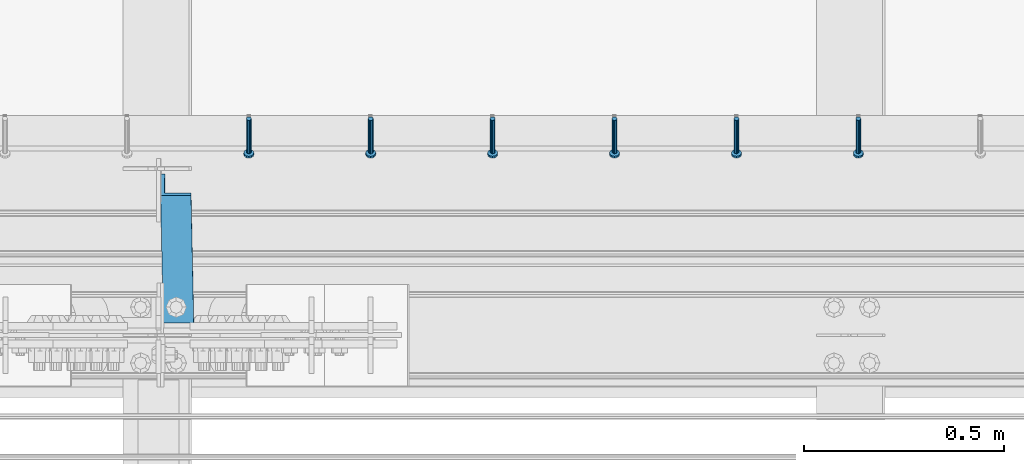
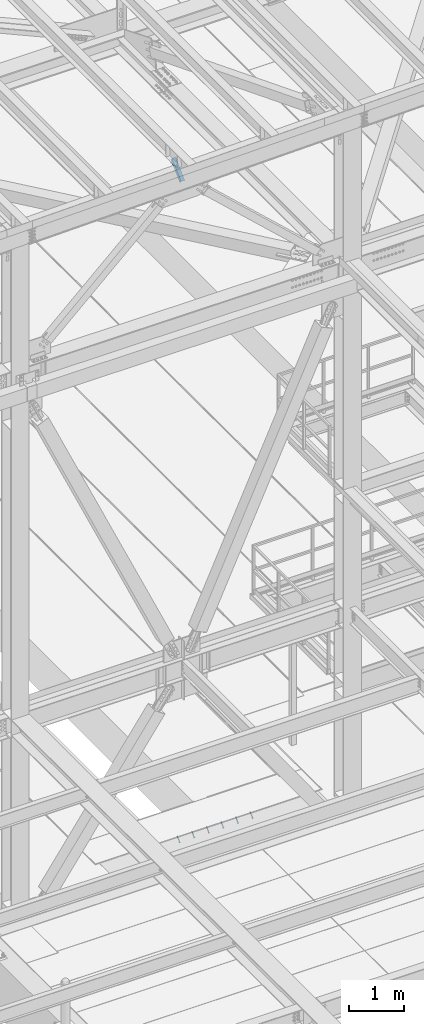
# One storey, part 2106 of 3843: 7 members, 2 elements without a shape of their own.
"""IFC2X3 building model written with IfcOpenShell, lengths in millimetres."""

from ifc_helpers import new_model, si_unit, frame, origin_with_axes, place, context, subcontext, project, spatial, faceted_brep, material, type_object, element, aggregate, save


model = new_model("IFC2X3")

# Units and contexts
model_context = context("Model", 3, precision=1e-05, world=origin_with_axes())
body_context = subcontext(model_context, "Body", "Model", "MODEL_VIEW")
ifc_project = project(units=[si_unit("LENGTHUNIT", "METRE", prefix="MILLI"), si_unit("AREAUNIT", "SQUARE_METRE"), si_unit("VOLUMEUNIT", "CUBIC_METRE"), si_unit("MASSUNIT", "GRAM", prefix="KILO"), si_unit("TIMEUNIT", "SECOND"), si_unit("PLANEANGLEUNIT", "RADIAN"), si_unit("SOLIDANGLEUNIT", "STERADIAN"), si_unit("THERMODYNAMICTEMPERATUREUNIT", "DEGREE_CELSIUS"), si_unit("LUMINOUSINTENSITYUNIT", "LUMEN")], contexts=[model_context])

# Site, building, storey
site_placement = place(None, origin_with_axes())
site = spatial("IfcSite", under=ifc_project, at=site_placement, CompositionType="ELEMENT")
building_placement = place(site_placement, origin_with_axes())
building = spatial("IfcBuilding", under=site, at=building_placement, Name="Undefined", CompositionType="ELEMENT")
storey_placement = place(building_placement, origin_with_axes())
storey = spatial("IfcBuildingStorey", under=building, at=storey_placement, Name="Undefined", CompositionType="ELEMENT", Elevation=0.0)

# Assembly, members
assembly_1_placement = place(storey_placement, origin_with_axes())
assembly_1 = element("IfcElementAssembly", 1, at=assembly_1_placement, inside=storey, Name="EMBED_ANGLE", AssemblyPlace="NOTDEFINED", PredefinedType="RIGID_FRAME")
ifc_material_1 = material(Name="STEEL/A108")
member_type_1 = type_object("IfcMemberType", PredefinedType="NOTDEFINED")
member_1_placement = place(assembly_1_placement, frame((47279.1789921875, 26157.2374995874, 30446.6625), z_axis=(-1.0, 0.0, 0.0), x_axis=(0.0, -0.707106781186548, -0.707106781186548)))
member_1 = element("IfcMember", 2, at=member_1_placement, type_object=member_type_1, material=ifc_material_1, Name="HEADED STUD ANCHOR", context=body_context, shape_type="Brep", body=[
    faceted_brep([(7.27595761418343e-12, -3.18000006675175, 5.5), (0.0, -5.49999999998363, 3.1800000667572), (118.110000000976, -5.49999999999091, 3.1800000667572), (118.110000000983, -3.18000006675175, 5.5), (0.0, -6.3499999046162, 0.0), (118.110000000968, -6.34999990461256, 0.0), (0.0, -5.49999999998363, -3.1800000667572), (118.110000000976, -5.49999999999091, -3.1800000667572), (7.27595761418343e-12, -3.18000006675175, -5.5), (118.110000000983, -3.18000006675175, -5.5), (7.27595761418343e-12, -1.81898940354586e-12, -6.34999990463257), (118.110000000968, -1.81898940354586e-12, -6.34999990463257), (0.0, 3.18000006675175, -5.5), (118.110000000968, 3.18000006674811, -5.5), (7.27595761418343e-12, 5.49999999998363, -3.1800000667572), (118.110000000983, 5.49999999998363, -3.1800000667572), (7.27595761418343e-12, 6.3499999046162, 0.0), (118.110000000976, 6.34999990461256, 0.0), (7.27595761418343e-12, 5.49999999998363, 3.1800000667572), (118.110000000983, 5.49999999998363, 3.1800000667572), (0.0, 3.18000006675175, 5.5), (118.110000000968, 3.18000006674811, 5.5), (7.27595761418343e-12, -1.81898940354586e-12, 6.34999990463257), (118.110000000968, -1.81898940354586e-12, 6.34999990463257), (120.650000000991, -10.9899997710909, 6.34999990463257), (120.650000000998, -6.34000015257152, 10.9899997711182), (120.650000000991, -12.6999998092379, 0.0), (120.650000000991, -10.9899997710909, -6.34999990463257), (120.650000000998, -6.34000015257152, -10.9899997711182), (120.650000000991, -1.81898940354586e-12, -12.6899995803833), (120.650000000991, 6.34000015257152, -10.9899997711182), (120.650000000998, 10.9899997710909, -6.34999990463257), (120.650000000991, 12.6999998092342, 0.0), (120.650000000998, 10.9899997710909, 6.34999990463257), (120.650000000991, 6.34000015257152, 10.9899997711182), (120.650000000991, -1.81898940354586e-12, 12.6899995803833), (127.000000001048, -10.9899997710945, 6.34999990463257), (127.000000001048, -6.34000015257152, 10.9899997711182), (127.000000001048, -12.6999998092342, 0.0), (127.000000001048, -10.9899997710945, -6.34999990463257), (127.000000001048, -6.34000015257152, -10.9899997711182), (127.000000001048, 1.81898940354586e-12, -12.6899995803833), (127.000000001048, 6.34000015256788, -10.9899997711182), (127.000000001048, 10.9899997710909, -6.34999990463257), (127.000000001048, 12.6999998092379, 0.0), (127.000000001048, 10.9899997710909, 6.34999990463257), (127.000000001048, 6.34000015256788, 10.9899997711182), (127.000000001048, 1.81898940354586e-12, 12.6899995803833)], [[[0, 1, 2, 3]], [[1, 4, 5, 2]], [[4, 6, 7, 5]], [[6, 8, 9, 7]], [[8, 10, 11, 9]], [[10, 12, 13, 11]], [[12, 14, 15, 13]], [[14, 16, 17, 15]], [[16, 18, 19, 17]], [[18, 20, 21, 19]], [[20, 22, 23, 21]], [[22, 0, 3, 23]], [[22, 20, 18, 16, 14, 12, 10, 8, 6, 4, 1, 0]], [[3, 2, 24, 25]], [[2, 5, 26, 24]], [[5, 7, 27, 26]], [[7, 9, 28, 27]], [[9, 11, 29, 28]], [[11, 13, 30, 29]], [[13, 15, 31, 30]], [[15, 17, 32, 31]], [[17, 19, 33, 32]], [[19, 21, 34, 33]], [[21, 23, 35, 34]], [[23, 3, 25, 35]], [[25, 24, 36, 37]], [[24, 26, 38, 36]], [[26, 27, 39, 38]], [[27, 28, 40, 39]], [[28, 29, 41, 40]], [[29, 30, 42, 41]], [[30, 31, 43, 42]], [[31, 32, 44, 43]], [[32, 33, 45, 44]], [[33, 34, 46, 45]], [[34, 35, 47, 46]], [[35, 25, 37, 47]], [[38, 39, 40, 41, 42, 43, 44, 45, 46, 47, 37, 36]]]),
])
member_2_placement = place(assembly_1_placement, frame((46974.3789921875, 26157.2374995874, 30446.6625), z_axis=(-1.0, 0.0, 0.0), x_axis=(0.0, -0.707106781186548, -0.707106781186548)))
member_2 = element("IfcMember", 3, at=member_2_placement, type_object=member_type_1, material=ifc_material_1, Name="HEADED STUD ANCHOR", context=body_context, shape_type="Brep", body=[
    faceted_brep([(7.27595761418343e-12, -3.18000006675175, 5.5), (0.0, -5.49999999998363, 3.1800000667572), (118.110000000976, -5.49999999999091, 3.1800000667572), (118.110000000983, -3.18000006675175, 5.5), (0.0, -6.3499999046162, 0.0), (118.110000000968, -6.34999990461256, 0.0), (0.0, -5.49999999998363, -3.1800000667572), (118.110000000976, -5.49999999999091, -3.1800000667572), (7.27595761418343e-12, -3.18000006675175, -5.5), (118.110000000983, -3.18000006675175, -5.5), (7.27595761418343e-12, -1.81898940354586e-12, -6.34999990463257), (118.110000000968, -1.81898940354586e-12, -6.34999990463257), (0.0, 3.18000006675175, -5.5), (118.110000000968, 3.18000006674811, -5.5), (7.27595761418343e-12, 5.49999999998363, -3.1800000667572), (118.110000000983, 5.49999999998363, -3.1800000667572), (7.27595761418343e-12, 6.3499999046162, 0.0), (118.110000000976, 6.34999990461256, 0.0), (7.27595761418343e-12, 5.49999999998363, 3.1800000667572), (118.110000000983, 5.49999999998363, 3.1800000667572), (0.0, 3.18000006675175, 5.5), (118.110000000968, 3.18000006674811, 5.5), (7.27595761418343e-12, -1.81898940354586e-12, 6.34999990463257), (118.110000000968, -1.81898940354586e-12, 6.34999990463257), (120.650000000991, -10.9899997710909, 6.34999990463257), (120.650000000998, -6.34000015257152, 10.9899997711182), (120.650000000991, -12.6999998092379, 0.0), (120.650000000991, -10.9899997710909, -6.34999990463257), (120.650000000998, -6.34000015257152, -10.9899997711182), (120.650000000991, -1.81898940354586e-12, -12.6899995803833), (120.650000000991, 6.34000015257152, -10.9899997711182), (120.650000000998, 10.9899997710909, -6.34999990463257), (120.650000000991, 12.6999998092342, 0.0), (120.650000000998, 10.9899997710909, 6.34999990463257), (120.650000000991, 6.34000015257152, 10.9899997711182), (120.650000000991, -1.81898940354586e-12, 12.6899995803833), (127.000000001048, -10.9899997710945, 6.34999990463257), (127.000000001048, -6.34000015257152, 10.9899997711182), (127.000000001048, -12.6999998092342, 0.0), (127.000000001048, -10.9899997710945, -6.34999990463257), (127.000000001048, -6.34000015257152, -10.9899997711182), (127.000000001048, 1.81898940354586e-12, -12.6899995803833), (127.000000001048, 6.34000015256788, -10.9899997711182), (127.000000001048, 10.9899997710909, -6.34999990463257), (127.000000001048, 12.6999998092379, 0.0), (127.000000001048, 10.9899997710909, 6.34999990463257), (127.000000001048, 6.34000015256788, 10.9899997711182), (127.000000001048, 1.81898940354586e-12, 12.6899995803833)], [[[0, 1, 2, 3]], [[1, 4, 5, 2]], [[4, 6, 7, 5]], [[6, 8, 9, 7]], [[8, 10, 11, 9]], [[10, 12, 13, 11]], [[12, 14, 15, 13]], [[14, 16, 17, 15]], [[16, 18, 19, 17]], [[18, 20, 21, 19]], [[20, 22, 23, 21]], [[22, 0, 3, 23]], [[22, 20, 18, 16, 14, 12, 10, 8, 6, 4, 1, 0]], [[3, 2, 24, 25]], [[2, 5, 26, 24]], [[5, 7, 27, 26]], [[7, 9, 28, 27]], [[9, 11, 29, 28]], [[11, 13, 30, 29]], [[13, 15, 31, 30]], [[15, 17, 32, 31]], [[17, 19, 33, 32]], [[19, 21, 34, 33]], [[21, 23, 35, 34]], [[23, 3, 25, 35]], [[25, 24, 36, 37]], [[24, 26, 38, 36]], [[26, 27, 39, 38]], [[27, 28, 40, 39]], [[28, 29, 41, 40]], [[29, 30, 42, 41]], [[30, 31, 43, 42]], [[31, 32, 44, 43]], [[32, 33, 45, 44]], [[33, 34, 46, 45]], [[34, 35, 47, 46]], [[35, 25, 37, 47]], [[38, 39, 40, 41, 42, 43, 44, 45, 46, 47, 37, 36]]]),
])
member_3_placement = place(assembly_1_placement, frame((46669.5789921875, 26157.2374995874, 30446.6625), z_axis=(-1.0, 0.0, 0.0), x_axis=(0.0, -0.707106781186548, -0.707106781186548)))
member_3 = element("IfcMember", 4, at=member_3_placement, type_object=member_type_1, material=ifc_material_1, Name="HEADED STUD ANCHOR", context=body_context, shape_type="Brep", body=[
    faceted_brep([(7.27595761418343e-12, -3.18000006675175, 5.5), (0.0, -5.49999999998363, 3.1800000667572), (118.110000000976, -5.49999999999091, 3.1800000667572), (118.110000000983, -3.18000006675175, 5.5), (0.0, -6.3499999046162, 0.0), (118.110000000968, -6.34999990461256, 0.0), (0.0, -5.49999999998363, -3.1800000667572), (118.110000000976, -5.49999999999091, -3.1800000667572), (7.27595761418343e-12, -3.18000006675175, -5.5), (118.110000000983, -3.18000006675175, -5.5), (7.27595761418343e-12, -1.81898940354586e-12, -6.34999990463257), (118.110000000968, -1.81898940354586e-12, -6.34999990463257), (0.0, 3.18000006675175, -5.5), (118.110000000968, 3.18000006674811, -5.5), (7.27595761418343e-12, 5.49999999998363, -3.1800000667572), (118.110000000983, 5.49999999998363, -3.1800000667572), (7.27595761418343e-12, 6.3499999046162, 0.0), (118.110000000976, 6.34999990461256, 0.0), (7.27595761418343e-12, 5.49999999998363, 3.1800000667572), (118.110000000983, 5.49999999998363, 3.1800000667572), (0.0, 3.18000006675175, 5.5), (118.110000000968, 3.18000006674811, 5.5), (7.27595761418343e-12, -1.81898940354586e-12, 6.34999990463257), (118.110000000968, -1.81898940354586e-12, 6.34999990463257), (120.650000000991, -10.9899997710909, 6.34999990463257), (120.650000000998, -6.34000015257152, 10.9899997711182), (120.650000000991, -12.6999998092379, 0.0), (120.650000000991, -10.9899997710909, -6.34999990463257), (120.650000000998, -6.34000015257152, -10.9899997711182), (120.650000000991, -1.81898940354586e-12, -12.6899995803833), (120.650000000991, 6.34000015257152, -10.9899997711182), (120.650000000998, 10.9899997710909, -6.34999990463257), (120.650000000991, 12.6999998092342, 0.0), (120.650000000998, 10.9899997710909, 6.34999990463257), (120.650000000991, 6.34000015257152, 10.9899997711182), (120.650000000991, -1.81898940354586e-12, 12.6899995803833), (127.000000001048, -10.9899997710945, 6.34999990463257), (127.000000001048, -6.34000015257152, 10.9899997711182), (127.000000001048, -12.6999998092342, 0.0), (127.000000001048, -10.9899997710945, -6.34999990463257), (127.000000001048, -6.34000015257152, -10.9899997711182), (127.000000001048, 1.81898940354586e-12, -12.6899995803833), (127.000000001048, 6.34000015256788, -10.9899997711182), (127.000000001048, 10.9899997710909, -6.34999990463257), (127.000000001048, 12.6999998092379, 0.0), (127.000000001048, 10.9899997710909, 6.34999990463257), (127.000000001048, 6.34000015256788, 10.9899997711182), (127.000000001048, 1.81898940354586e-12, 12.6899995803833)], [[[0, 1, 2, 3]], [[1, 4, 5, 2]], [[4, 6, 7, 5]], [[6, 8, 9, 7]], [[8, 10, 11, 9]], [[10, 12, 13, 11]], [[12, 14, 15, 13]], [[14, 16, 17, 15]], [[16, 18, 19, 17]], [[18, 20, 21, 19]], [[20, 22, 23, 21]], [[22, 0, 3, 23]], [[22, 20, 18, 16, 14, 12, 10, 8, 6, 4, 1, 0]], [[3, 2, 24, 25]], [[2, 5, 26, 24]], [[5, 7, 27, 26]], [[7, 9, 28, 27]], [[9, 11, 29, 28]], [[11, 13, 30, 29]], [[13, 15, 31, 30]], [[15, 17, 32, 31]], [[17, 19, 33, 32]], [[19, 21, 34, 33]], [[21, 23, 35, 34]], [[23, 3, 25, 35]], [[25, 24, 36, 37]], [[24, 26, 38, 36]], [[26, 27, 39, 38]], [[27, 28, 40, 39]], [[28, 29, 41, 40]], [[29, 30, 42, 41]], [[30, 31, 43, 42]], [[31, 32, 44, 43]], [[32, 33, 45, 44]], [[33, 34, 46, 45]], [[34, 35, 47, 46]], [[35, 25, 37, 47]], [[38, 39, 40, 41, 42, 43, 44, 45, 46, 47, 37, 36]]]),
])
member_4_placement = place(assembly_1_placement, frame((46364.7789921875, 26157.2374995874, 30446.6625), z_axis=(-1.0, 0.0, 0.0), x_axis=(0.0, -0.707106781186548, -0.707106781186548)))
member_4 = element("IfcMember", 5, at=member_4_placement, type_object=member_type_1, material=ifc_material_1, Name="HEADED STUD ANCHOR", context=body_context, shape_type="Brep", body=[
    faceted_brep([(7.27595761418343e-12, -3.18000006675175, 5.5), (0.0, -5.49999999998363, 3.1800000667572), (118.110000000976, -5.49999999999091, 3.1800000667572), (118.110000000983, -3.18000006675175, 5.5), (0.0, -6.3499999046162, 0.0), (118.110000000968, -6.34999990461256, 0.0), (0.0, -5.49999999998363, -3.1800000667572), (118.110000000976, -5.49999999999091, -3.1800000667572), (7.27595761418343e-12, -3.18000006675175, -5.5), (118.110000000983, -3.18000006675175, -5.5), (7.27595761418343e-12, -1.81898940354586e-12, -6.34999990463257), (118.110000000968, -1.81898940354586e-12, -6.34999990463257), (0.0, 3.18000006675175, -5.5), (118.110000000968, 3.18000006674811, -5.5), (7.27595761418343e-12, 5.49999999998363, -3.1800000667572), (118.110000000983, 5.49999999998363, -3.1800000667572), (7.27595761418343e-12, 6.3499999046162, 0.0), (118.110000000976, 6.34999990461256, 0.0), (7.27595761418343e-12, 5.49999999998363, 3.1800000667572), (118.110000000983, 5.49999999998363, 3.1800000667572), (0.0, 3.18000006675175, 5.5), (118.110000000968, 3.18000006674811, 5.5), (7.27595761418343e-12, -1.81898940354586e-12, 6.34999990463257), (118.110000000968, -1.81898940354586e-12, 6.34999990463257), (120.650000000991, -10.9899997710909, 6.34999990463257), (120.650000000998, -6.34000015257152, 10.9899997711182), (120.650000000991, -12.6999998092379, 0.0), (120.650000000991, -10.9899997710909, -6.34999990463257), (120.650000000998, -6.34000015257152, -10.9899997711182), (120.650000000991, -1.81898940354586e-12, -12.6899995803833), (120.650000000991, 6.34000015257152, -10.9899997711182), (120.650000000998, 10.9899997710909, -6.34999990463257), (120.650000000991, 12.6999998092342, 0.0), (120.650000000998, 10.9899997710909, 6.34999990463257), (120.650000000991, 6.34000015257152, 10.9899997711182), (120.650000000991, -1.81898940354586e-12, 12.6899995803833), (127.000000001048, -10.9899997710945, 6.34999990463257), (127.000000001048, -6.34000015257152, 10.9899997711182), (127.000000001048, -12.6999998092342, 0.0), (127.000000001048, -10.9899997710945, -6.34999990463257), (127.000000001048, -6.34000015257152, -10.9899997711182), (127.000000001048, 1.81898940354586e-12, -12.6899995803833), (127.000000001048, 6.34000015256788, -10.9899997711182), (127.000000001048, 10.9899997710909, -6.34999990463257), (127.000000001048, 12.6999998092379, 0.0), (127.000000001048, 10.9899997710909, 6.34999990463257), (127.000000001048, 6.34000015256788, 10.9899997711182), (127.000000001048, 1.81898940354586e-12, 12.6899995803833)], [[[0, 1, 2, 3]], [[1, 4, 5, 2]], [[4, 6, 7, 5]], [[6, 8, 9, 7]], [[8, 10, 11, 9]], [[10, 12, 13, 11]], [[12, 14, 15, 13]], [[14, 16, 17, 15]], [[16, 18, 19, 17]], [[18, 20, 21, 19]], [[20, 22, 23, 21]], [[22, 0, 3, 23]], [[22, 20, 18, 16, 14, 12, 10, 8, 6, 4, 1, 0]], [[3, 2, 24, 25]], [[2, 5, 26, 24]], [[5, 7, 27, 26]], [[7, 9, 28, 27]], [[9, 11, 29, 28]], [[11, 13, 30, 29]], [[13, 15, 31, 30]], [[15, 17, 32, 31]], [[17, 19, 33, 32]], [[19, 21, 34, 33]], [[21, 23, 35, 34]], [[23, 3, 25, 35]], [[25, 24, 36, 37]], [[24, 26, 38, 36]], [[26, 27, 39, 38]], [[27, 28, 40, 39]], [[28, 29, 41, 40]], [[29, 30, 42, 41]], [[30, 31, 43, 42]], [[31, 32, 44, 43]], [[32, 33, 45, 44]], [[33, 34, 46, 45]], [[34, 35, 47, 46]], [[35, 25, 37, 47]], [[38, 39, 40, 41, 42, 43, 44, 45, 46, 47, 37, 36]]]),
])
member_5_placement = place(assembly_1_placement, frame((46059.9789921875, 26157.2374995874, 30446.6625), z_axis=(-1.0, 0.0, 0.0), x_axis=(0.0, -0.707106781186548, -0.707106781186548)))
member_5 = element("IfcMember", 6, at=member_5_placement, type_object=member_type_1, material=ifc_material_1, Name="HEADED STUD ANCHOR", context=body_context, shape_type="Brep", body=[
    faceted_brep([(7.27595761418343e-12, -3.18000006675175, 5.5), (0.0, -5.49999999998363, 3.1800000667572), (118.110000000976, -5.49999999999091, 3.1800000667572), (118.110000000983, -3.18000006675175, 5.5), (0.0, -6.3499999046162, 0.0), (118.110000000968, -6.34999990461256, 0.0), (0.0, -5.49999999998363, -3.1800000667572), (118.110000000976, -5.49999999999091, -3.1800000667572), (7.27595761418343e-12, -3.18000006675175, -5.5), (118.110000000983, -3.18000006675175, -5.5), (7.27595761418343e-12, -1.81898940354586e-12, -6.34999990463257), (118.110000000968, -1.81898940354586e-12, -6.34999990463257), (0.0, 3.18000006675175, -5.5), (118.110000000968, 3.18000006674811, -5.5), (7.27595761418343e-12, 5.49999999998363, -3.1800000667572), (118.110000000983, 5.49999999998363, -3.1800000667572), (7.27595761418343e-12, 6.3499999046162, 0.0), (118.110000000976, 6.34999990461256, 0.0), (7.27595761418343e-12, 5.49999999998363, 3.1800000667572), (118.110000000983, 5.49999999998363, 3.1800000667572), (0.0, 3.18000006675175, 5.5), (118.110000000968, 3.18000006674811, 5.5), (7.27595761418343e-12, -1.81898940354586e-12, 6.34999990463257), (118.110000000968, -1.81898940354586e-12, 6.34999990463257), (120.650000000991, -10.9899997710909, 6.34999990463257), (120.650000000998, -6.34000015257152, 10.9899997711182), (120.650000000991, -12.6999998092379, 0.0), (120.650000000991, -10.9899997710909, -6.34999990463257), (120.650000000998, -6.34000015257152, -10.9899997711182), (120.650000000991, -1.81898940354586e-12, -12.6899995803833), (120.650000000991, 6.34000015257152, -10.9899997711182), (120.650000000998, 10.9899997710909, -6.34999990463257), (120.650000000991, 12.6999998092342, 0.0), (120.650000000998, 10.9899997710909, 6.34999990463257), (120.650000000991, 6.34000015257152, 10.9899997711182), (120.650000000991, -1.81898940354586e-12, 12.6899995803833), (127.000000001048, -10.9899997710945, 6.34999990463257), (127.000000001048, -6.34000015257152, 10.9899997711182), (127.000000001048, -12.6999998092342, 0.0), (127.000000001048, -10.9899997710945, -6.34999990463257), (127.000000001048, -6.34000015257152, -10.9899997711182), (127.000000001048, 1.81898940354586e-12, -12.6899995803833), (127.000000001048, 6.34000015256788, -10.9899997711182), (127.000000001048, 10.9899997710909, -6.34999990463257), (127.000000001048, 12.6999998092379, 0.0), (127.000000001048, 10.9899997710909, 6.34999990463257), (127.000000001048, 6.34000015256788, 10.9899997711182), (127.000000001048, 1.81898940354586e-12, 12.6899995803833)], [[[0, 1, 2, 3]], [[1, 4, 5, 2]], [[4, 6, 7, 5]], [[6, 8, 9, 7]], [[8, 10, 11, 9]], [[10, 12, 13, 11]], [[12, 14, 15, 13]], [[14, 16, 17, 15]], [[16, 18, 19, 17]], [[18, 20, 21, 19]], [[20, 22, 23, 21]], [[22, 0, 3, 23]], [[22, 20, 18, 16, 14, 12, 10, 8, 6, 4, 1, 0]], [[3, 2, 24, 25]], [[2, 5, 26, 24]], [[5, 7, 27, 26]], [[7, 9, 28, 27]], [[9, 11, 29, 28]], [[11, 13, 30, 29]], [[13, 15, 31, 30]], [[15, 17, 32, 31]], [[17, 19, 33, 32]], [[19, 21, 34, 33]], [[21, 23, 35, 34]], [[23, 3, 25, 35]], [[25, 24, 36, 37]], [[24, 26, 38, 36]], [[26, 27, 39, 38]], [[27, 28, 40, 39]], [[28, 29, 41, 40]], [[29, 30, 42, 41]], [[30, 31, 43, 42]], [[31, 32, 44, 43]], [[32, 33, 45, 44]], [[33, 34, 46, 45]], [[34, 35, 47, 46]], [[35, 25, 37, 47]], [[38, 39, 40, 41, 42, 43, 44, 45, 46, 47, 37, 36]]]),
])
member_6_placement = place(assembly_1_placement, frame((45755.1789921875, 26157.2374995874, 30446.6625), z_axis=(-1.0, 0.0, 0.0), x_axis=(0.0, -0.707106781186548, -0.707106781186548)))
member_6 = element("IfcMember", 7, at=member_6_placement, type_object=member_type_1, material=ifc_material_1, Name="HEADED STUD ANCHOR", context=body_context, shape_type="Brep", body=[
    faceted_brep([(7.27595761418343e-12, -3.18000006675175, 5.5), (0.0, -5.49999999998363, 3.1800000667572), (118.110000000976, -5.49999999999091, 3.1800000667572), (118.110000000983, -3.18000006675175, 5.5), (0.0, -6.3499999046162, 0.0), (118.110000000968, -6.34999990461256, 0.0), (0.0, -5.49999999998363, -3.1800000667572), (118.110000000976, -5.49999999999091, -3.1800000667572), (7.27595761418343e-12, -3.18000006675175, -5.5), (118.110000000983, -3.18000006675175, -5.5), (7.27595761418343e-12, -1.81898940354586e-12, -6.34999990463257), (118.110000000968, -1.81898940354586e-12, -6.34999990463257), (0.0, 3.18000006675175, -5.5), (118.110000000968, 3.18000006674811, -5.5), (7.27595761418343e-12, 5.49999999998363, -3.1800000667572), (118.110000000983, 5.49999999998363, -3.1800000667572), (7.27595761418343e-12, 6.3499999046162, 0.0), (118.110000000976, 6.34999990461256, 0.0), (7.27595761418343e-12, 5.49999999998363, 3.1800000667572), (118.110000000983, 5.49999999998363, 3.1800000667572), (0.0, 3.18000006675175, 5.5), (118.110000000968, 3.18000006674811, 5.5), (7.27595761418343e-12, -1.81898940354586e-12, 6.34999990463257), (118.110000000968, -1.81898940354586e-12, 6.34999990463257), (120.650000000991, -10.9899997710909, 6.34999990463257), (120.650000000998, -6.34000015257152, 10.9899997711182), (120.650000000991, -12.6999998092379, 0.0), (120.650000000991, -10.9899997710909, -6.34999990463257), (120.650000000998, -6.34000015257152, -10.9899997711182), (120.650000000991, -1.81898940354586e-12, -12.6899995803833), (120.650000000991, 6.34000015257152, -10.9899997711182), (120.650000000998, 10.9899997710909, -6.34999990463257), (120.650000000991, 12.6999998092342, 0.0), (120.650000000998, 10.9899997710909, 6.34999990463257), (120.650000000991, 6.34000015257152, 10.9899997711182), (120.650000000991, -1.81898940354586e-12, 12.6899995803833), (127.000000001048, -10.9899997710945, 6.34999990463257), (127.000000001048, -6.34000015257152, 10.9899997711182), (127.000000001048, -12.6999998092342, 0.0), (127.000000001048, -10.9899997710945, -6.34999990463257), (127.000000001048, -6.34000015257152, -10.9899997711182), (127.000000001048, 1.81898940354586e-12, -12.6899995803833), (127.000000001048, 6.34000015256788, -10.9899997711182), (127.000000001048, 10.9899997710909, -6.34999990463257), (127.000000001048, 12.6999998092379, 0.0), (127.000000001048, 10.9899997710909, 6.34999990463257), (127.000000001048, 6.34000015256788, 10.9899997711182), (127.000000001048, 1.81898940354586e-12, 12.6899995803833)], [[[0, 1, 2, 3]], [[1, 4, 5, 2]], [[4, 6, 7, 5]], [[6, 8, 9, 7]], [[8, 10, 11, 9]], [[10, 12, 13, 11]], [[12, 14, 15, 13]], [[14, 16, 17, 15]], [[16, 18, 19, 17]], [[18, 20, 21, 19]], [[20, 22, 23, 21]], [[22, 0, 3, 23]], [[22, 20, 18, 16, 14, 12, 10, 8, 6, 4, 1, 0]], [[3, 2, 24, 25]], [[2, 5, 26, 24]], [[5, 7, 27, 26]], [[7, 9, 28, 27]], [[9, 11, 29, 28]], [[11, 13, 30, 29]], [[13, 15, 31, 30]], [[15, 17, 32, 31]], [[17, 19, 33, 32]], [[19, 21, 34, 33]], [[21, 23, 35, 34]], [[23, 3, 25, 35]], [[25, 24, 36, 37]], [[24, 26, 38, 36]], [[26, 27, 39, 38]], [[27, 28, 40, 39]], [[28, 29, 41, 40]], [[29, 30, 42, 41]], [[30, 31, 43, 42]], [[31, 32, 44, 43]], [[32, 33, 45, 44]], [[33, 34, 46, 45]], [[34, 35, 47, 46]], [[35, 25, 37, 47]], [[38, 39, 40, 41, 42, 43, 44, 45, 46, 47, 37, 36]]]),
])
aggregate(assembly_1, [member_1, member_2, member_3, member_4, member_5, member_6])

# Assembly, member
assembly_2_placement = place(storey_placement, origin_with_axes())
assembly_2 = element("IfcElementAssembly", 8, at=assembly_2_placement, inside=storey, Name="ANGLE", AssemblyPlace="NOTDEFINED", PredefinedType="RIGID_FRAME")
ifc_material_2 = material(Name="STEEL/A572-50")
member_type_2 = type_object("IfcMemberType", Name="L3X3X3/8", PredefinedType="NOTDEFINED")
member_7_placement = place(assembly_2_placement, frame((45569.0603023668, 26187.4884149004, 45764.3379117122), z_axis=(0.0149567919991071, 0.70710678095505, -0.706948579955064), x_axis=(0.0149567919892506, -0.707106781418042, -0.706948579492178)))
member_7 = element("IfcMember", 9, at=member_7_placement, type_object=member_type_2, material=ifc_material_2, Name="ANGLE", ObjectType="L3X3X3/8", context=body_context, shape_type="Brep", body=[
    faceted_brep([(276.741870175065, 38.0999999989435, -38.0999999994419), (276.741870179554, -38.1000000005151, -38.0999999994856), (276.741870185811, -38.1000000005006, -28.5749999994769), (276.74187018189, 28.5749999990367, -28.5749999994441), (276.74187022572, 28.5749999991822, 38.1000000005624), (276.74187022516, 38.0999999991036, 38.1000000005697), (727.591870170465, 28.5749999980617, 38.1000000014537), (727.591870169912, 38.0999999979686, 38.100000001461), (727.591870173688, 38.0999999978085, -38.0999999985506), (727.59187017817, -38.1000000016502, -38.099999998587), (727.591870177697, -38.1000000016211, -28.5749999985856), (727.591870173776, 28.5749999978871, -28.5749999985528)], [[[0, 1, 2, 3, 4, 5]], [[5, 4, 6, 7]], [[0, 5, 7, 8]], [[1, 0, 8, 9]], [[2, 1, 9, 10]], [[3, 2, 10, 11]], [[4, 3, 11, 6]], [[10, 9, 8, 7, 6, 11]]]),
])
aggregate(assembly_2, [member_7])

save(model, "model.ifc")
